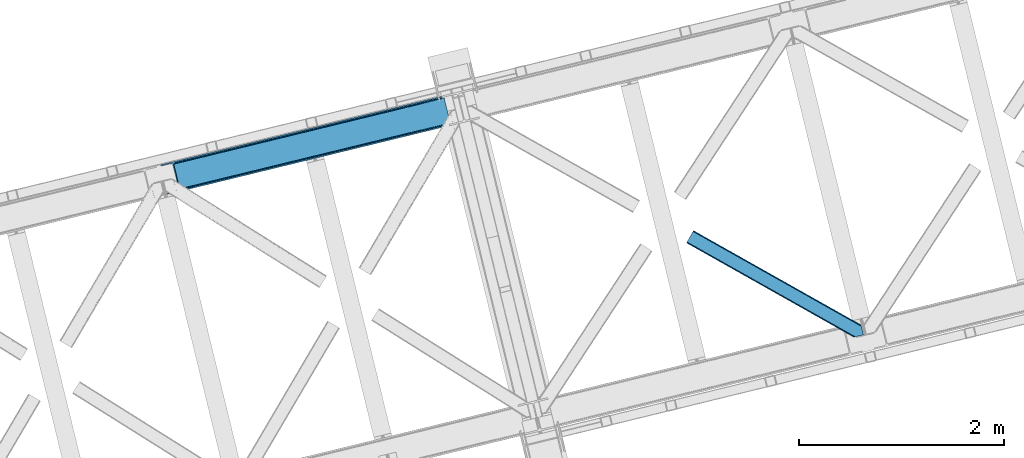
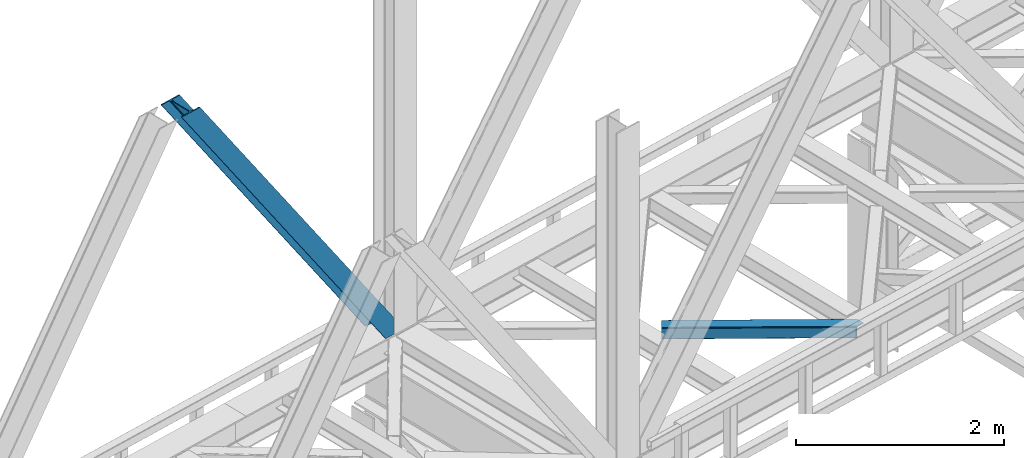
# One storey, part 39 of 92: 2 members.
"""IFC4 building model written with IfcOpenShell, lengths in millimetres."""

from ifc_helpers import new_model, entity, si_unit, converted_unit, derived_unit, direction, frame, origin, place, context, subcontext, project, spatial, triangles, type_object, element, save


model = new_model("IFC4")

# Units and contexts
model_context = context("Model", 3, precision=0.01, world=origin(), true_north=direction((6.12303176911189e-17, 1.0)))
plan_context = context("Plan", 3, precision=0.01, world=origin(), true_north=direction((6.12303176911189e-17, 1.0)))
body_context = subcontext(model_context, "Body", "Model", "MODEL_VIEW")
ifc_project = project(units=[si_unit("LENGTHUNIT", "METRE", prefix="MILLI"), si_unit("AREAUNIT", "SQUARE_METRE"), si_unit("VOLUMEUNIT", "CUBIC_METRE"), converted_unit("PLANEANGLEUNIT", "DEGREE", entity("IfcRatioMeasure", 0.0174532925199433), si_unit("PLANEANGLEUNIT", "RADIAN"), dimensions=[0, 0, 0, 0, 0, 0, 0]), si_unit("MASSUNIT", "GRAM", prefix="KILO"), derived_unit("MASSDENSITYUNIT", [(si_unit("MASSUNIT", "GRAM", prefix="KILO"), 1), (si_unit("LENGTHUNIT", "METRE"), -3)]), derived_unit("MOMENTOFINERTIAUNIT", [(si_unit("LENGTHUNIT", "METRE"), 4)]), si_unit("TIMEUNIT", "SECOND"), si_unit("FREQUENCYUNIT", "HERTZ"), si_unit("THERMODYNAMICTEMPERATUREUNIT", "DEGREE_CELSIUS"), derived_unit("THERMALTRANSMITTANCEUNIT", [(si_unit("MASSUNIT", "GRAM", prefix="KILO"), 1), (si_unit("THERMODYNAMICTEMPERATUREUNIT", "KELVIN"), -1), (si_unit("TIMEUNIT", "SECOND"), -3)]), derived_unit("VOLUMETRICFLOWRATEUNIT", [(si_unit("LENGTHUNIT", "METRE"), 3), (si_unit("TIMEUNIT", "SECOND"), -1)]), derived_unit("MASSFLOWRATEUNIT", [(si_unit("MASSUNIT", "GRAM", prefix="KILO"), 1), (si_unit("TIMEUNIT", "SECOND"), -1)]), derived_unit("ROTATIONALFREQUENCYUNIT", [(si_unit("TIMEUNIT", "SECOND"), -1)]), si_unit("ELECTRICCURRENTUNIT", "AMPERE"), si_unit("ELECTRICVOLTAGEUNIT", "VOLT"), si_unit("POWERUNIT", "WATT"), si_unit("FORCEUNIT", "NEWTON", prefix="KILO"), si_unit("ILLUMINANCEUNIT", "LUX"), si_unit("LUMINOUSFLUXUNIT", "LUMEN"), si_unit("LUMINOUSINTENSITYUNIT", "CANDELA"), derived_unit("USERDEFINED", [(si_unit("MASSUNIT", "GRAM", prefix="KILO"), -1), (si_unit("LENGTHUNIT", "METRE"), -2), (si_unit("TIMEUNIT", "SECOND"), 3), (si_unit("LUMINOUSFLUXUNIT", "LUMEN"), 1)]), derived_unit("LINEARVELOCITYUNIT", [(si_unit("LENGTHUNIT", "METRE"), 1), (si_unit("TIMEUNIT", "SECOND"), -1)]), si_unit("PRESSUREUNIT", "PASCAL"), derived_unit("USERDEFINED", [(si_unit("LENGTHUNIT", "METRE"), -2), (si_unit("MASSUNIT", "GRAM", prefix="KILO"), 1), (si_unit("TIMEUNIT", "SECOND"), -2)]), derived_unit("LINEARFORCEUNIT", [(si_unit("MASSUNIT", "GRAM", prefix="KILO"), 1), (si_unit("LENGTHUNIT", "METRE"), 1), (si_unit("TIMEUNIT", "SECOND"), -2), (si_unit("LENGTHUNIT", "METRE"), -1)]), derived_unit("PLANARFORCEUNIT", [(si_unit("MASSUNIT", "GRAM", prefix="KILO"), 1), (si_unit("LENGTHUNIT", "METRE"), 1), (si_unit("TIMEUNIT", "SECOND"), -2), (si_unit("LENGTHUNIT", "METRE"), -2)])], contexts=[model_context, plan_context])

# Site, building, storey
site_placement = place(None, origin())
site = spatial("IfcSite", under=ifc_project, at=site_placement, CompositionType="ELEMENT")
building_placement = place(site_placement, origin())
building = spatial("IfcBuilding", under=site, at=building_placement, CompositionType="ELEMENT")
storey_placement = place(building_placement, frame((0.0, 0.0, 15900.0)))
storey = spatial("IfcBuildingStorey", under=building, at=storey_placement, Name="05", CompositionType="ELEMENT", Elevation=15900.0)

# Members
member_type_1 = type_object("IfcMemberType", PredefinedType="BRACE")
member_1_placement = place(storey_placement, frame((-52278.84, 7914.04, 3695.0)))
element("IfcMember", 1, at=member_1_placement, inside=storey, type_object=member_type_1, ObjectType="Steel Vertical Brace", PredefinedType="BRACE", context=body_context, shape_type="Tessellation", body=[
    triangles([(2824.17180175782, 696.209248352051, 0.781347656247817), (2824.8368774414, 695.227912902831, 1.0697021484375), (2823.33929443359, 694.862818908691, 0.0), (2821.44638671875, 702.635018920898, 0.0), (2812.38182373047, 692.19088897705, 19.5569458007813), (2812.38182373047, 692.19088897705, 0.0), (2386.756640625, 583.574263000489, 658.75048828125), (2392.34234619141, 580.919773864746, 662.07819213867), (2803.98698730469, 681.26248626709, 51.2480346679658), (2804.11721191406, 683.186787414551, 44.4996093749978), (2382.25924072265, 588.488497924805, 656.525042724606), (2808.48903808594, 690.380534362793, 26.4030395507798), (2805.01948242188, 685.664543151855, 38.2720825195283), (2805.58688964844, 687.218518066406, 34.3676696777329), (630.519653320313, 150.046073913574, 3288.98063964843), (624.696752929689, 150.036772155761, 3285.05529785156), (211.3359375, 47.8656829833981, 3911.00081176758), (202.866687011723, 47.2110717773439, 3911.00081176758), (619.11104736328, 152.691842651367, 3281.72759399414), (195.039257812503, 49.3190826416012, 3911.00081176758), (614.613647460938, 157.60549621582, 3279.50447387695), (189.03962402344, 53.868223571777, 3911.00081176758), (611.888232421879, 164.031266784667, 3278.7231262207), (185.788659667967, 60.1655136108393, 3911.00081176758), (2804.10791015625, 679.881175231933, 63.6403015136711), (2398.16524658203, 580.929075622559, 666.003533935545), (1956.25733642578, 473.208325195313, 1321.74955444336), (1950.42978515625, 473.1990234375, 1317.82188720703), (1508.521875, 365.478273010253, 1973.56790771484), (1514.34477539063, 365.487574768066, 1977.49324951172), (1066.60931396484, 257.757522583008, 2629.3116027832), (1072.43221435547, 257.76682434082, 2633.23694458008), (1944.84873046875, 475.854093933106, 1314.49418334961), (1502.93151855469, 368.132762145996, 1970.23787841797), (1061.02360839844, 260.412011718749, 2625.98389892578), (1940.3466796875, 480.767747497558, 1312.27106323242), (1498.43411865235, 373.046997070312, 1968.01475830078), (1056.52620849609, 265.326246643066, 2623.75845336914), (2379.5338256836, 594.914268493651, 655.74602050781), (1937.62126464844, 487.193518066407, 1311.48971557617), (1495.71335449219, 379.47276763916, 1967.23341064453), (1053.80079345703, 271.752017211914, 2622.97710571289), (2766.268359375, 929.006666564942, 0.0), (2324.35579833984, 821.285916137695, 655.74602050781), (1882.44323730469, 713.565165710449, 1311.48971557617), (1440.53067626953, 605.844415283203, 1967.23341064453), (998.618115234378, 498.123664855956, 2622.97710571289), (556.705554199223, 390.402914428711, 3278.7231262207), (130.61063232422, 286.537161254883, 3911.00081176758), (303.26520996094, 70.2747802734375, 3911.00081176758), (2804.10791015625, 679.881175231933, 200.055230712889), (2807.14028320312, 667.240086364746, 200.120343017577), (2804.29859619141, 678.898677062988, 200.120343017577), (306.344091796876, 57.6447372436523, 3911.00081176758), (2807.14028320312, 667.240086364746, 0.0), (2804.29859619141, 678.898677062988, 0.0), (2804.0009399414, 682.093249511719, 0.0), (2804.11721191406, 683.186787414551, 2.42078247070094), (2804.72182617187, 685.456997680664, 5.12991943359157), (2805.58688964844, 687.218518066406, 5.67639770507594), (2807.01936035157, 689.087008666992, 4.89505004882813), (2808.48903808594, 690.380534362793, 3.35328369140552), (2811.04237060547, 691.772309875488, 0.0), (2705.52322998047, 642.470086669921, 0.0), (69.865502929686, 0.0, 3911.00081176758), (2794.37827148438, 677.509226989746, 0.0), (2802.00106201172, 681.140400695801, 0.0), (2702.44434814453, 655.100129699706, 0.0), (66.78662109375, 12.6306243896479, 3911.00081176758), (1480.00268554688, 357.117155456544, 1950.37164916992), (1034.29035644532, 248.469717407226, 2611.75686035156), (588.578027343749, 139.82227935791, 3273.1420715332), (158.720544433592, 35.0397216796873, 3911.00081176758), (1925.71966552734, 465.76459350586, 1288.98643798828), (2371.43199462891, 574.412031555176, 627.598901367186), (2376.60842285156, 577.083380126954, 631.526568603513), (2380.34307861328, 582.010986328124, 634.854272460936), (2381.53835449219, 595.402610778808, 637.858740234373), (2811.39583740234, 700.185168457031, 0.0), (2811.09818115235, 693.083857727051, 0.0), (2382.07785644531, 588.443733215331, 637.077392578125), (598.684387207031, 160.812858581543, 3283.40191040039), (599.21923828125, 153.853981018066, 3282.62056274414), (175.738110351565, 57.7156631469725, 3911.00081176758), (175.752062988286, 50.6283050537104, 3911.00081176758), (597.489111328126, 147.421234130859, 3280.39744262695), (172.519702148442, 43.8304641723635, 3911.00081176758), (593.749804687504, 142.493627929687, 3277.06973876953), (166.538671875001, 38.3563796997068, 3911.00081176758), (1936.36087646485, 479.796295166015, 1298.46260375976), (1935.82602539063, 486.755172729491, 1299.24395141601), (1490.64854736329, 371.148857116698, 1959.85014038086), (1490.10904541016, 378.107734680175, 1960.63148803711), (1044.3967163086, 269.460296630859, 2622.01669921875), (1044.93621826172, 262.501419067383, 2621.2353515625), (1934.63074951172, 473.363548278808, 1296.23948364258), (1488.91376953125, 364.716110229491, 1957.62469482422), (1043.20144042969, 256.068672180176, 2619.01223144531), (1930.89144287109, 468.435942077637, 1292.91177978515), (1485.17911376953, 359.788504028321, 1954.2969909668), (1039.46678466797, 251.141065979004, 2615.68220214844), (2756.2178100586, 926.556816101073, 0.0), (2326.36032714844, 821.774258422852, 637.858740234373), (1434.93101806641, 604.479382324219, 1960.63148803711), (1880.64334716797, 713.126820373535, 1299.24395141601), (989.214038085942, 495.831944274903, 2622.01669921875), (543.501708984375, 387.184506225586, 3283.40191040039), (120.560083007811, 284.087310791015, 3911.00081176758), (2752.68314208985, 932.723881530762, 0.0), (2753.40867919922, 934.106936645508, 0.0), (2752.03201904297, 933.86276550293, 0.0), (2764.37080078125, 936.778866577149, 0.0), (2753.40867919922, 934.106936645508, 19.5569458007813), (2765.86838378906, 937.143960571289, 1.0697021484375), (2765.72885742188, 935.96612548828, 0.781347656247817), (2325.55107421875, 834.677540588379, 658.75048828125), (2749.12521972656, 933.923808288574, 26.4030395507798), (2745.08825683594, 935.395230102539, 34.3676696777329), (2323.81629638672, 828.244793701172, 656.525042724606), (2743.51160888672, 936.560275268555, 38.5441589355469), (556.170703125004, 397.36237335205, 3279.50447387695), (130.5966796875, 293.624519348144, 3911.00081176758), (557.900830078128, 403.794538879395, 3281.72759399414), (133.829040527344, 300.422360229492, 3911.00081176758), (561.64013671875, 408.722145080566, 3285.05529785156), (139.810070800784, 305.896444702149, 3911.00081176758), (566.811914062499, 411.393493652343, 3288.98063964843), (147.628198242186, 309.213102722169, 3911.00081176758), (2740.93037109375, 939.947277832031, 51.2480346679658), (2740.40017089844, 941.228594970703, 63.6403015136711), (2329.28572998047, 839.605146789551, 662.07819213867), (2334.46215820313, 842.276495361329, 666.003533935545), (2742.09309082032, 938.421789550782, 45.5251281738274), (1881.90373535157, 720.524043273926, 1312.27106323242), (1439.9911743164, 612.803874206543, 1968.01475830078), (998.083264160159, 505.083123779296, 2623.75845336914), (1883.63851318359, 726.956790161133, 1314.49418334961), (1441.72595214844, 619.236039733886, 1970.23787841797), (999.813391113283, 511.51528930664, 2625.98389892578), (1887.37316894531, 731.883815002441, 1317.82188720703), (1445.46060791016, 624.163064575195, 1973.56790771484), (1003.5526977539, 516.442895507812, 2629.3116027832), (1892.54959716797, 734.555744934082, 1321.74955444336), (1450.63703613282, 626.834994506836, 1977.49324951172), (1008.72447509766, 519.114244079589, 2633.23694458008), (2740.40017089844, 941.228594970703, 200.055230712889), (239.562121582036, 331.622200012206, 3911.00081176758), (2749.12521972656, 933.923808288574, 3.35328369140552), (2745.08825683594, 935.395230102539, 5.67639770507594), (2747.22766113281, 934.392965698243, 4.89272460937354), (2743.51160888672, 936.560275268555, 5.12991943359157), (2740.12111816406, 942.189001464844, 0.0), (2741.9303100586, 938.297959899902, 2.42078247070094), (2740.12111816406, 942.189001464844, 200.120343017577), (2741.32569580078, 939.216508483886, 0.0), (2323.63026123047, 828.200028991699, 637.077392578125), (2319.13286132813, 833.114263916016, 634.854272460936), (2313.54715576172, 835.768753051757, 631.526568603513), (2307.7242553711, 835.759451293946, 627.598901367186), (2730.67053222656, 938.856646728515, 0.0), (2739.11187744141, 939.141513061523, 0.0), (524.870288085942, 401.16969909668, 3273.1420715332), (530.693188476565, 401.179000854491, 3277.06973876953), (103.482055664063, 297.041171264648, 3911.00081176758), (95.0128051757856, 296.387141418457, 3911.00081176758), (536.278894042967, 398.524511718751, 3280.39744262695), (111.309484863283, 294.933741760254, 3911.00081176758), (540.776293945317, 393.610276794433, 3282.62056274414), (117.309118652345, 290.384600830078, 3911.00081176758), (1862.01192626953, 727.112013244629, 1288.98643798828), (1867.83482666016, 727.121315002441, 1292.91177978515), (1416.29959716797, 618.464575195313, 1950.37164916992), (1422.12249755859, 618.473876953124, 1954.2969909668), (976.405517578125, 509.826438903808, 2615.68220214844), (970.582617187501, 509.817137145997, 2611.75686035156), (1873.42053222656, 724.4668258667, 1296.23948364258), (1427.708203125, 615.819387817383, 1957.62469482422), (981.995874023436, 507.171949768067, 2619.01223144531), (1877.9179321289, 719.552590942382, 1298.46260375976), (1432.20560302735, 610.905152893066, 1959.85014038086), (986.493273925786, 502.257714843749, 2621.2353515625), (2737.27943115235, 953.84817352295, 200.120343017577), (236.483239746092, 344.252824401855, 3911.00081176758), (2737.27943115235, 953.84817352295, 0.0), (0.0, 286.608087158203, 3911.00081176758), (3.07888183593604, 273.978044128417, 3911.00081176758), (2635.66237792969, 929.077592468261, 0.0), (2638.74125976563, 916.447549438476, 0.0)], [[1, 2, 3], [3, 4, 1], [2, 5, 6], [6, 3, 2], [7, 8, 9], [9, 10, 7], [11, 12, 5], [5, 1, 11], [5, 2, 1], [11, 7, 13], [13, 14, 11], [14, 12, 11], [15, 16, 17], [18, 17, 16], [16, 19, 18], [20, 18, 19], [19, 21, 20], [22, 20, 21], [21, 23, 22], [24, 22, 23], [10, 13, 7], [25, 9, 8], [8, 26, 25], [26, 8, 27], [28, 27, 8], [27, 28, 29], [29, 30, 27], [30, 29, 31], [31, 32, 30], [32, 31, 15], [16, 15, 31], [8, 7, 33], [33, 28, 8], [28, 33, 29], [34, 29, 33], [29, 34, 31], [35, 31, 34], [31, 35, 16], [19, 16, 35], [7, 11, 36], [36, 33, 7], [33, 36, 37], [37, 34, 33], [34, 37, 35], [38, 35, 37], [35, 38, 21], [21, 19, 35], [1, 4, 11], [39, 11, 4], [11, 39, 36], [40, 36, 39], [36, 40, 37], [41, 37, 40], [37, 41, 42], [42, 38, 37], [38, 42, 21], [23, 21, 42], [4, 43, 44], [45, 39, 44], [41, 40, 45], [41, 45, 46], [44, 39, 4], [45, 40, 39], [42, 41, 46], [46, 47, 42], [47, 48, 23], [49, 24, 48], [47, 23, 42], [48, 24, 23], [50, 51, 30], [30, 32, 50], [32, 15, 50], [17, 50, 15], [27, 30, 51], [51, 25, 26], [26, 27, 51], [52, 53, 54], [53, 51, 50], [50, 54, 53], [52, 55, 53], [56, 53, 55], [56, 9, 25], [56, 57, 58], [58, 10, 56], [10, 9, 56], [59, 60, 14], [14, 13, 59], [10, 58, 59], [60, 61, 12], [12, 14, 60], [5, 62, 63], [63, 6, 5], [5, 12, 62], [61, 62, 12], [13, 10, 59], [25, 51, 53], [53, 56, 25], [54, 64, 52], [54, 65, 64], [64, 55, 52], [56, 66, 67], [55, 66, 56], [67, 57, 56], [64, 66, 55], [64, 68, 66], [68, 64, 69], [65, 69, 64], [69, 70, 68], [71, 69, 72], [69, 71, 70], [69, 73, 72], [74, 68, 70], [66, 68, 75], [74, 75, 68], [67, 76, 58], [76, 77, 59], [59, 58, 76], [76, 67, 66], [78, 79, 80], [81, 60, 59], [81, 80, 62], [62, 61, 81], [61, 60, 81], [80, 63, 62], [59, 77, 81], [80, 81, 78], [82, 83, 84], [85, 84, 83], [83, 86, 85], [87, 85, 86], [86, 88, 87], [89, 87, 88], [88, 72, 89], [73, 89, 72], [66, 75, 76], [58, 57, 67], [78, 81, 90], [90, 91, 78], [91, 90, 92], [92, 93, 91], [93, 92, 94], [95, 94, 92], [94, 95, 83], [83, 82, 94], [81, 77, 90], [96, 90, 77], [90, 96, 92], [97, 92, 96], [92, 97, 95], [98, 95, 97], [95, 98, 83], [86, 83, 98], [77, 76, 96], [99, 96, 76], [96, 99, 100], [100, 97, 96], [97, 100, 101], [101, 98, 97], [98, 101, 88], [88, 86, 98], [76, 75, 74], [74, 99, 76], [99, 74, 70], [70, 100, 99], [100, 70, 101], [71, 101, 70], [101, 71, 72], [72, 88, 101], [102, 79, 78], [91, 103, 78], [104, 105, 91], [104, 91, 93], [78, 103, 102], [91, 105, 103], [106, 104, 93], [93, 94, 106], [94, 82, 107], [84, 108, 82], [94, 107, 106], [82, 108, 107], [109, 102, 110], [6, 79, 80], [6, 80, 63], [110, 111, 109], [3, 79, 6], [79, 4, 102], [3, 4, 79], [43, 102, 4], [102, 112, 110], [112, 102, 43], [113, 114, 110], [112, 110, 114], [114, 115, 112], [43, 112, 115], [116, 117, 118], [119, 115, 113], [113, 116, 119], [113, 117, 116], [115, 114, 113], [118, 120, 116], [48, 121, 122], [122, 49, 48], [121, 123, 124], [124, 122, 121], [123, 125, 126], [126, 124, 123], [125, 127, 128], [128, 126, 125], [129, 130, 131], [132, 131, 130], [133, 116, 120], [116, 133, 129], [131, 116, 129], [43, 115, 119], [119, 44, 43], [44, 119, 134], [134, 45, 44], [45, 134, 46], [135, 46, 134], [46, 135, 47], [136, 47, 135], [47, 136, 121], [121, 48, 47], [119, 116, 134], [137, 134, 116], [134, 137, 135], [138, 135, 137], [135, 138, 139], [139, 136, 135], [136, 139, 123], [123, 121, 136], [116, 131, 140], [140, 137, 116], [137, 140, 141], [141, 138, 137], [138, 141, 142], [142, 139, 138], [139, 142, 123], [125, 123, 142], [131, 132, 143], [143, 140, 131], [140, 143, 141], [144, 141, 143], [141, 144, 142], [145, 142, 144], [142, 145, 127], [127, 125, 142], [144, 146, 147], [147, 127, 145], [127, 147, 128], [145, 144, 147], [146, 144, 143], [143, 132, 146], [130, 146, 132], [113, 110, 111], [148, 117, 113], [149, 118, 117], [117, 148, 150], [151, 133, 120], [118, 149, 151], [151, 120, 118], [152, 133, 153], [152, 129, 133], [146, 130, 154], [152, 154, 130], [130, 129, 152], [153, 155, 152], [151, 153, 133], [117, 150, 149], [111, 148, 113], [156, 150, 148], [156, 149, 150], [148, 109, 156], [148, 111, 109], [156, 157, 151], [151, 149, 156], [103, 156, 109], [158, 159, 160], [158, 153, 151], [158, 161, 153], [161, 155, 153], [151, 157, 158], [160, 161, 158], [162, 163, 164], [164, 165, 162], [163, 166, 167], [167, 164, 163], [166, 168, 169], [169, 167, 166], [168, 107, 108], [108, 169, 168], [109, 102, 103], [159, 158, 170], [171, 170, 158], [170, 171, 172], [173, 172, 171], [172, 173, 174], [174, 175, 172], [175, 174, 162], [163, 162, 174], [158, 157, 176], [176, 171, 158], [171, 176, 173], [177, 173, 176], [173, 177, 174], [178, 174, 177], [174, 178, 163], [166, 163, 178], [157, 156, 179], [179, 176, 157], [176, 179, 180], [180, 177, 176], [177, 180, 181], [181, 178, 177], [178, 181, 168], [168, 166, 178], [156, 103, 179], [105, 179, 103], [179, 105, 180], [104, 180, 105], [180, 104, 106], [106, 181, 180], [181, 106, 168], [107, 168, 106], [146, 154, 147], [154, 182, 183], [183, 147, 154], [154, 152, 184], [184, 182, 154], [108, 84, 49], [87, 89, 18], [73, 65, 54], [69, 65, 73], [89, 73, 17], [84, 85, 22], [85, 87, 20], [167, 126, 164], [185, 165, 183], [165, 164, 128], [185, 186, 165], [167, 169, 124], [169, 108, 122], [49, 84, 24], [17, 18, 89], [22, 85, 20], [18, 20, 87], [22, 24, 84], [54, 17, 73], [54, 50, 17], [128, 164, 126], [124, 169, 122], [49, 122, 108], [124, 126, 167], [128, 183, 165], [183, 128, 147], [152, 160, 184], [155, 161, 152], [152, 161, 160], [160, 187, 184], [187, 160, 188], [183, 187, 185], [187, 183, 182], [184, 187, 182], [172, 186, 188], [162, 186, 175], [162, 165, 186], [172, 175, 186], [188, 170, 172], [159, 170, 188], [188, 160, 159], [187, 188, 185], [186, 185, 188]]),
])
member_type_2 = type_object("IfcMemberType", PredefinedType="BRACE")
member_2_placement = place(storey_placement, frame((-47153.99, 6520.94, 3511.0)))
element("IfcMember", 2, at=member_2_placement, inside=storey, type_object=member_type_2, ObjectType="Steel Horizontal Brace", PredefinedType="BRACE", context=body_context, shape_type="Tessellation", body=[
    triangles([(1645.8158203125, 3.74512023925763, 138.667117309571), (1655.3408203125, 6.06707153320258, 139.999594116212), (8.58552246094041, 933.436047363281, 139.999594116212), (5.302001953125, 927.600938415527, 138.667117309571), (1637.74189453125, 1.7772171020506, 134.874325561526), (2.51612548828416, 922.654147338867, 134.874325561526), (1632.346875, 0.462181091308594, 129.197927856447), (0.651123046875, 919.348535156249, 129.197927856447), (1630.44931640625, 0.0, 122.500662231447), (0.0, 918.188140869141, 122.500662231447), (1630.44931640625, 0.0, 17.5000946044929), (0.0, 918.188140869141, 17.5000946044929), (1706.57025146484, 97.721360778808, 139.999594116212), (1724.78774414062, 22.9951080322262, 139.999594116212), (60.1079589843794, 1024.92639312744, 139.999594116212), (1701.3287109375, 119.229350280762, 129.197927856447), (1700.89617919922, 121.001335144043, 122.500662231447), (68.0423583984375, 1039.01390533447, 129.197927856447), (68.6981323242217, 1040.17429962158, 122.500662231447), (1702.55654296875, 114.182565307617, 134.874325561526), (66.1820068359375, 1035.70829315186, 134.874325561526), (1704.39829101563, 106.63011932373, 138.667117309571), (63.3961303710967, 1030.7615020752, 138.667117309571), (1700.89617919922, 121.001335144043, 17.5000946044929), (68.6981323242217, 1040.17429962158, 17.5000946044929), (0.651123046875, 919.348535156249, 10.8028289794929), (1633.02590332031, 0.628450012206486, 10.9377044677749), (2.51612548828416, 922.654147338867, 5.12526855468968), (5.302001953125, 927.600938415527, 1.33247680664135), (1569.79720458984, 46.5547164916989, 1.33247680664135), (1573.68999023438, 34.8100845336912, 8.52041015625218), (1571.51337890625, 39.517936706543, 5.59500732422021), (1572.2900756836, 36.3402236938473, 7.52047119140843), (1573.35047607422, 35.1804107666012, 8.278564453125), (1572.98770751953, 35.5751541137688, 8.02044067383031), (1572.62493896484, 35.9693161010737, 7.76231689453198), (1633.97468261719, 0.859831237792605, 8.52041015625218), (1567.62524414063, 55.4634750366204, 0.0), (8.58552246094041, 933.436047363281, 0.0), (1533.57615966797, 195.142739868164, 0.0), (60.1079589843794, 1024.92639312744, 0.0), (1566.72762451172, 59.1411575317379, 7.52047119140843), (1567.24387207031, 57.3430114746088, 7.90300598144677), (1567.78337402344, 56.4360900878901, 8.1076446533225), (1568.32752685547, 55.5204483032221, 8.31460876464917), (1568.41124267579, 55.3762710571282, 8.3471649169951), (1568.86237792969, 54.6129455566406, 8.52041015625218), (1655.15013427735, 6.02056274414008, 8.52041015625218), (5.94847412109812, 928.753193664551, 12.1260040283232), (1647.69477539063, 4.20381317138617, 12.1260040283232), (8.73435058593896, 933.700566101074, 8.3320495605476), (12.0225219726563, 939.535675048828, 6.99957275390625), (1565.35561523437, 64.7751159667969, 6.99957275390625), (1642.29975585938, 2.88877716064417, 17.8035644531265), (4.08812255859812, 925.448162841797, 17.8035644531265), (1640.40684814454, 2.42717742919922, 24.4996673583992), (3.43234863281396, 924.287187194824, 24.4996673583992), (1640.40684814454, 2.42717742919922, 115.501089477541), (3.43234863281396, 924.287187194824, 115.501089477541), (1647.69477539063, 4.20381317138617, 127.87475280762), (1655.77335205078, 6.17229766845685, 131.667544555665), (1642.29975585938, 2.88877716064417, 122.196029663086), (1665.29835205078, 8.4942489624018, 133.000021362306), (1724.78774414062, 22.9951080322262, 133.000021362306), (4.08812255859812, 925.448162841797, 122.196029663086), (5.94847412109812, 928.753193664551, 127.87475280762), (8.73435058593896, 933.700566101074, 131.667544555665), (12.0225219726563, 939.535675048828, 133.000021362306), (1708.8398803711, 88.4097198486324, 133.000021362306), (56.6756103515654, 1018.82676544189, 133.000021362306), (1535.84578857422, 185.831098937988, 6.99957275390625), (56.6756103515654, 1018.82676544189, 6.99957275390625), (68.0423583984375, 1039.01390533447, 10.8028289794929), (62.7450073242217, 1029.60924682617, 12.1260040283232), (64.6100097656235, 1032.91427764893, 17.8035644531265), (65.2611328124985, 1034.0752532959, 24.4996673583992), (66.1820068359375, 1035.70829315186, 5.12526855468968), (63.3961303710967, 1030.7615020752, 1.33247680664135), (59.9591308593735, 1024.66187438965, 8.3320495605476), (62.7450073242217, 1029.60924682617, 127.87475280762), (65.2611328124985, 1034.0752532959, 115.501089477541), (64.6100097656235, 1032.91427764893, 122.196029663086), (59.9591308593735, 1024.66187438965, 131.667544555665), (1703.16580810547, 111.689694213866, 24.4996673583992), (1703.16580810547, 111.689694213866, 115.501089477541), (1706.66791992188, 97.318478393554, 131.667544555665), (1704.826171875, 104.870924377441, 127.87475280762), (1703.59833984375, 109.917127990722, 122.196029663086), (1704.826171875, 104.870924377441, 12.1260040283232), (1706.52839355469, 97.8998382568352, 8.52041015625218), (1701.70078125, 117.702699279785, 8.52041015625218), (1703.59833984375, 109.917127990722, 17.8035644531265), (1701.48218994141, 118.590435791015, 10.9365417480476), (1534.47377929687, 191.465057373047, 7.52047119140843), (1529.69267578125, 211.088278198242, 5.59500732422021), (1528.9159790039, 214.265991210938, 7.52047119140843), (1531.40419921875, 204.051498413086, 1.33247680664135), (1529.11596679688, 214.689221191406, 8.22740478515698), (1529.01364746094, 214.477606201172, 7.87393798828271), (1529.90196533204, 214.452026367188, 8.52041015625218), (1534.34820556641, 192.705679321289, 7.85649719238427), (1534.72957763672, 194.649165344238, 8.52041015625218)], [[1, 2, 3], [3, 4, 1], [5, 1, 4], [4, 6, 5], [7, 5, 6], [6, 8, 7], [9, 7, 8], [8, 10, 9], [11, 9, 12], [10, 12, 9], [2, 13, 3], [2, 14, 13], [15, 3, 13], [16, 17, 18], [19, 18, 17], [20, 16, 21], [18, 21, 16], [22, 20, 23], [21, 23, 20], [13, 22, 15], [23, 15, 22], [17, 24, 19], [25, 19, 24], [26, 27, 11], [28, 29, 30], [27, 26, 31], [26, 28, 32], [32, 33, 26], [34, 26, 35], [34, 31, 26], [26, 36, 35], [26, 33, 36], [31, 37, 27], [30, 32, 28], [38, 30, 29], [29, 39, 38], [11, 12, 26], [40, 38, 39], [39, 41, 40], [33, 42, 43], [36, 43, 44], [35, 44, 45], [34, 46, 47], [34, 45, 46], [47, 31, 34], [45, 34, 35], [44, 35, 36], [43, 36, 33], [48, 37, 47], [31, 47, 37], [49, 50, 47], [47, 51, 49], [47, 46, 51], [50, 48, 47], [52, 43, 42], [51, 46, 45], [45, 52, 51], [45, 44, 52], [43, 52, 44], [42, 53, 52], [54, 50, 49], [49, 55, 54], [56, 54, 55], [55, 57, 56], [58, 56, 59], [57, 59, 56], [60, 61, 1], [5, 60, 1], [5, 7, 62], [60, 5, 62], [62, 7, 9], [61, 2, 1], [14, 63, 64], [14, 2, 63], [61, 63, 2], [62, 9, 58], [56, 11, 54], [9, 56, 58], [11, 27, 54], [9, 11, 56], [37, 54, 27], [50, 54, 37], [48, 50, 37], [62, 58, 65], [59, 65, 58], [60, 62, 66], [65, 66, 62], [61, 60, 67], [66, 67, 60], [63, 61, 68], [67, 68, 61], [69, 63, 68], [63, 69, 64], [68, 70, 69], [53, 71, 52], [72, 52, 71], [73, 74, 75], [76, 19, 25], [73, 75, 25], [73, 77, 74], [75, 76, 25], [74, 77, 78], [72, 41, 39], [41, 79, 78], [79, 41, 72], [79, 74, 78], [18, 80, 21], [81, 19, 76], [19, 82, 18], [82, 19, 81], [18, 82, 80], [15, 70, 3], [23, 21, 80], [80, 83, 23], [83, 70, 15], [15, 23, 83], [49, 29, 28], [39, 52, 72], [39, 51, 52], [51, 39, 29], [49, 51, 29], [57, 12, 10], [26, 55, 49], [28, 26, 49], [55, 26, 12], [57, 55, 12], [4, 66, 6], [3, 70, 68], [68, 67, 3], [67, 66, 4], [4, 3, 67], [8, 6, 66], [10, 59, 57], [65, 10, 8], [10, 65, 59], [65, 8, 66], [84, 85, 81], [81, 76, 84], [86, 69, 70], [70, 83, 86], [87, 86, 83], [83, 80, 87], [88, 87, 80], [80, 82, 88], [85, 88, 82], [82, 81, 85], [87, 20, 22], [89, 90, 91], [20, 87, 88], [86, 87, 22], [86, 13, 69], [14, 69, 13], [69, 14, 64], [86, 22, 13], [24, 17, 84], [91, 92, 89], [92, 24, 84], [93, 92, 91], [93, 24, 92], [17, 85, 84], [88, 16, 20], [17, 16, 88], [85, 17, 88], [40, 71, 53], [94, 95, 96], [40, 94, 71], [94, 97, 95], [94, 40, 97], [38, 40, 53], [42, 38, 53], [32, 42, 33], [42, 30, 38], [42, 32, 30], [73, 25, 24], [98, 99, 77], [96, 77, 99], [96, 95, 77], [73, 93, 100], [100, 77, 73], [100, 98, 77], [93, 91, 100], [78, 77, 95], [97, 40, 41], [41, 78, 97], [95, 97, 78], [24, 93, 73], [72, 71, 94], [94, 79, 72], [101, 102, 79], [79, 94, 101], [74, 79, 102], [90, 89, 102], [74, 102, 89], [92, 84, 75], [76, 75, 84], [89, 92, 74], [75, 74, 92], [101, 94, 99], [102, 101, 99], [91, 90, 102], [102, 100, 91]]),
])

save(model, "model.ifc")
